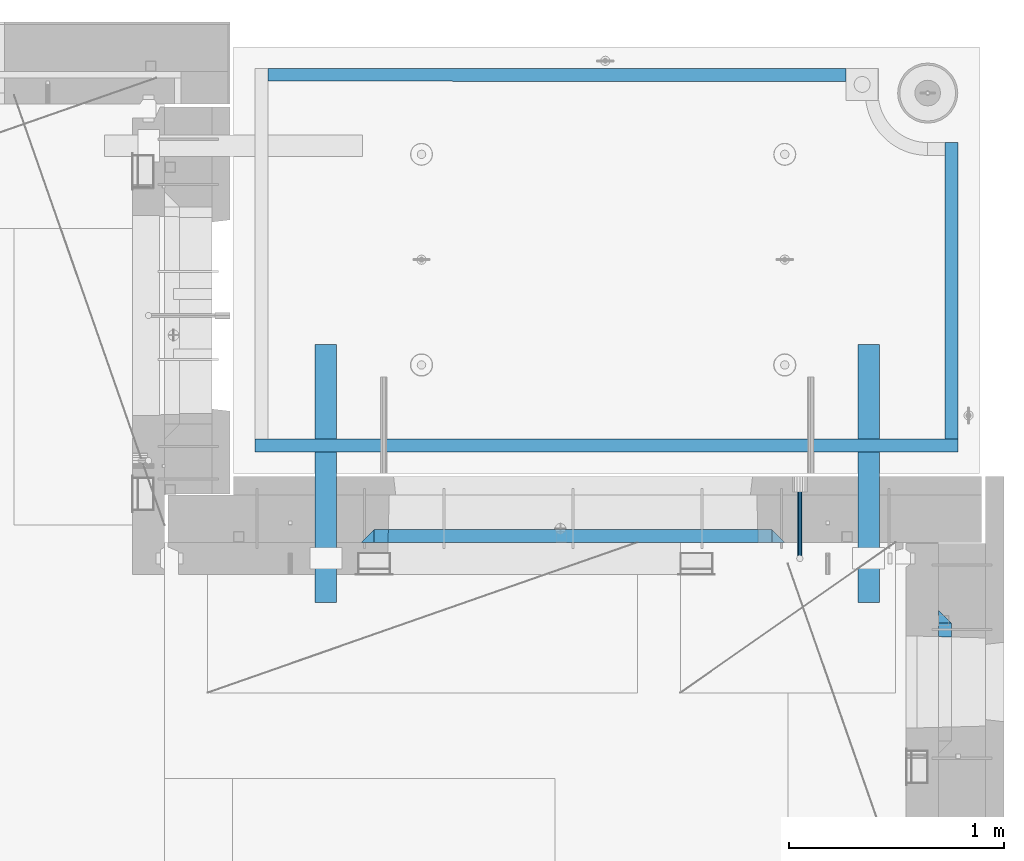
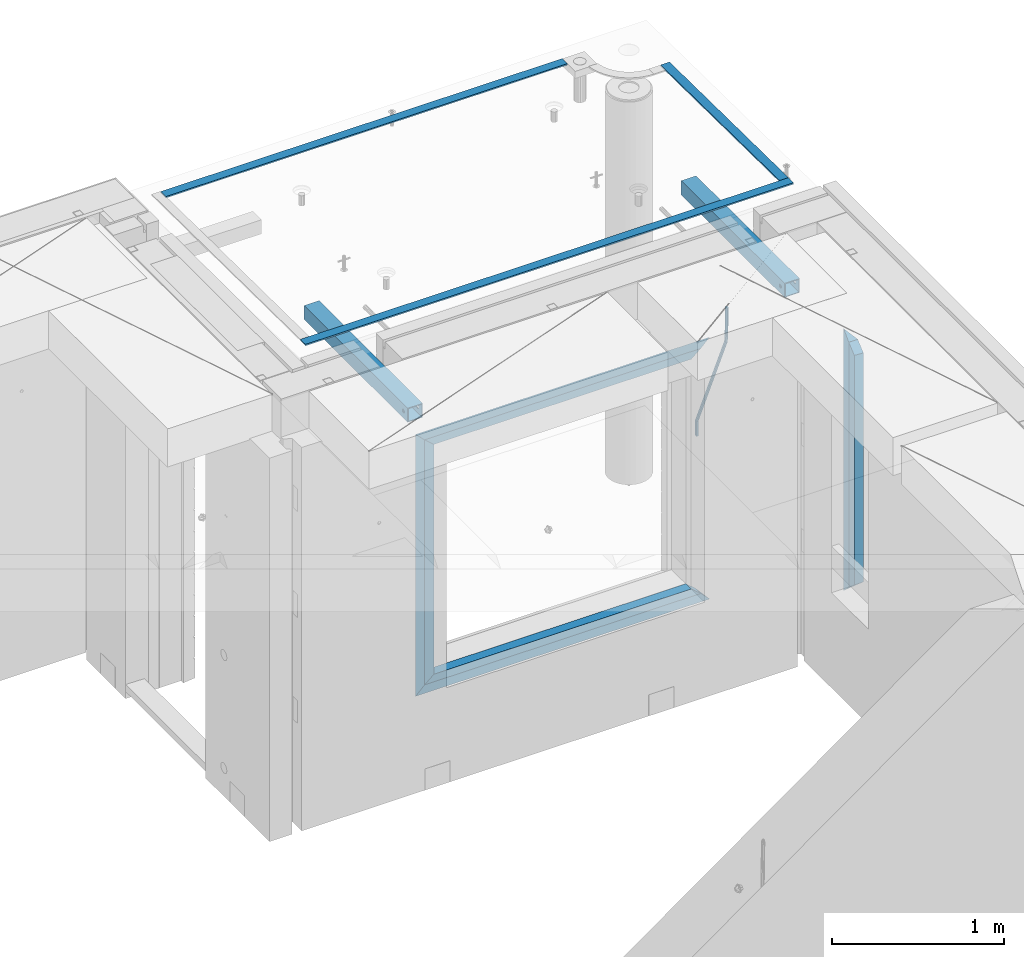
# One storey, part 135 of 350: 14 beams, 5 elements without a shape of their own.
"""IFC2X3 building model written with IfcOpenShell, lengths in millimetres."""

import ifcopenshell
import ifcopenshell.guid

model = None  # the IFC model being written
_history = None  # IfcOwnerHistory: only IFC2X3 demands one
_inside = {}  # id of a spatial element -> (the spatial element, [elements in it])
_under = {}  # id of a project, library or spatial element -> (it, [spatial elements below it])
_declared = {}  # id of a project -> (the project, [libraries it declares])
_typed = {}  # id of a type object -> (the type object, [elements of that type])
_made_of = {}  # id of a material, layer set ... -> (it, [elements and type objects made of it])


def new_model(schema):
    """Start an empty IFC model of exactly this schema.

    Asked for "IFC4X3", IfcOpenShell would pick the latest addendum, in which some entities
    have other attributes; the version numbers below select the first issue.
    IFC2X3 requires an IfcOwnerHistory on every rooted entity: one is made here for all.
    """
    global model, _history
    if schema == "IFC4X3":
        model = ifcopenshell.file(schema_version=(4, 3, 0, 0))
    else:
        model = ifcopenshell.file(schema=schema)
    _inside.clear()
    _under.clear()
    _declared.clear()
    _typed.clear()
    _made_of.clear()
    _history = None
    if model.schema == "IFC2X3":
        org = make("IfcOrganization", Name="unknown")
        user = make(
            "IfcPersonAndOrganization",
            ThePerson=make("IfcPerson", FamilyName="unknown"),
            TheOrganization=org,
        )
        app = make(
            "IfcApplication",
            ApplicationDeveloper=org,
            Version="unknown",
            ApplicationFullName="unknown",
            ApplicationIdentifier="unknown",
        )
        _history = make(
            "IfcOwnerHistory",
            OwningUser=user,
            OwningApplication=app,
            ChangeAction="ADDED",
            CreationDate=0,
        )
    return model


def make(cls, **values):
    """One entity of the class cls with the attributes given. An attribute that is None is left unset."""
    return model.create_entity(
        cls, **{name: value for name, value in values.items() if value is not None}
    )


def rooted(cls, **values):
    """An entity with a GlobalId (a new one), such as an element, a storey or a relation."""
    return make(cls, GlobalId=ifcopenshell.guid.new(), OwnerHistory=_history, **values)


def si_unit(unit_type, name, prefix=None):
    """IfcSIUnit, for example si_unit("LENGTHUNIT", "METRE", prefix="MILLI")."""
    return make("IfcSIUnit", UnitType=unit_type, Prefix=prefix, Name=name)


def assignment(units):
    """IfcUnitAssignment: the units of a project."""
    return None if units is None else make("IfcUnitAssignment", Units=units)


def point(xyz):
    """IfcCartesianPoint."""
    return None if xyz is None else make("IfcCartesianPoint", Coordinates=xyz)


def direction(xyz):
    """IfcDirection."""
    return None if xyz is None else make("IfcDirection", DirectionRatios=xyz)


def frame(location, z_axis=None, x_axis=None):
    """IfcAxis2Placement3D, a coordinate frame: its origin and axes. An axis left out is left unset."""
    return make(
        "IfcAxis2Placement3D",
        Location=point(location),
        Axis=direction(z_axis),
        RefDirection=direction(x_axis),
    )


def origin_with_axes():
    """The frame at (0, 0, 0) with the z axis (0, 0, 1) and the x axis (1, 0, 0) written out."""
    return frame((0.0, 0.0, 0.0), z_axis=(0.0, 0.0, 1.0), x_axis=(1.0, 0.0, 0.0))


def place(relative_to, where):
    """IfcLocalPlacement: puts the frame where relative to a parent placement (None: the world)."""
    return make(
        "IfcLocalPlacement", PlacementRelTo=relative_to, RelativePlacement=where
    )


def context(
    kind, dimensions, precision=None, world=None, true_north=None, identifier=None
):
    """IfcGeometricRepresentationContext, for example the 3D "Model" context."""
    return make(
        "IfcGeometricRepresentationContext",
        ContextIdentifier=identifier,
        ContextType=kind,
        CoordinateSpaceDimension=dimensions,
        Precision=precision,
        WorldCoordinateSystem=world,
        TrueNorth=true_north,
    )


def subcontext(parent, identifier, kind, view, scale=None):
    """IfcGeometricRepresentationSubContext, for example "Body" below "Model"."""
    return make(
        "IfcGeometricRepresentationSubContext",
        ContextIdentifier=identifier,
        ContextType=kind,
        ParentContext=parent,
        TargetScale=scale,
        TargetView=view,
    )


def project(units=None, contexts=None):
    """IfcProject with its units and contexts."""
    return rooted(
        "IfcProject",
        Name="project",
        RepresentationContexts=contexts,
        UnitsInContext=assignment(units),
    )


def spatial(cls, under=None, at=None, **own):
    """A site, building, storey or space (cls), placed at a placement, below another one or the project."""
    s = rooted(cls, ObjectPlacement=at, **own)
    if under is not None:
        _under.setdefault(under.id(), (under, []))[1].append(s)
    return s


def faces_of(points, faces, orient=None, outer=None):
    """IfcFace entities. A face is a list of loops; a loop is a list of indices into points, from 0.

    orient and outer hold one flag for each loop. By default every Orientation is true, the
    first loop of a face is its IfcFaceOuterBound and the others are IfcFaceBound.
    """
    made = []
    for i, loops in enumerate(faces):
        bounds = []
        for j, loop in enumerate(loops):
            is_outer = j == 0 if outer is None else outer[i][j]
            bounds.append(
                make(
                    "IfcFaceOuterBound" if is_outer else "IfcFaceBound",
                    Bound=make("IfcPolyLoop", Polygon=[points[k] for k in loop]),
                    Orientation=True if orient is None else orient[i][j],
                )
            )
        made.append(make("IfcFace", Bounds=bounds))
    return made


def faceted_brep(points, faces, orient=None, outer=None, voids=None):
    """IfcFacetedBrep: a solid bounded by flat faces; with voids (closed shells), ...WithVoids."""
    shared = [point(p) for p in points]
    hull = make("IfcClosedShell", CfsFaces=faces_of(shared, faces, orient, outer))
    if voids is None:
        return make("IfcFacetedBrep", Outer=hull)
    return make(
        "IfcFacetedBrepWithVoids",
        Outer=hull,
        Voids=[
            make(cls, CfsFaces=faces_of(shared, fs, o, b)) for cls, fs, o, b in voids
        ],
    )


def shape(context_of_items, identifier, shape_type, items):
    """IfcShapeRepresentation: the items that make up one representation, for example the "Body"."""
    return make(
        "IfcShapeRepresentation",
        ContextOfItems=context_of_items,
        RepresentationIdentifier=identifier,
        RepresentationType=shape_type,
        Items=items,
    )


def material(Name=None, Category=None):
    """IfcMaterial."""
    return make("IfcMaterial", Name=Name, Category=Category)


def made_of(thing, what):
    """Note that an element or type object is made of a material, layer set ...; save() writes the relation."""
    if what is not None:
        _made_of.setdefault(what.id(), (what, []))[1].append(thing)
    return thing


def type_object(cls, material=None, **own):
    """A type object (cls), such as IfcWallType, which elements share."""
    return made_of(rooted(cls, **own), material)


def element(
    cls,
    number,
    at=None,
    inside=None,
    cuts=None,
    type_object=None,
    material=None,
    context=None,
    identifier="Body",
    shape_type=None,
    held_by="IfcProductDefinitionShape",
    body=None,
    shapes=None,
    **own,
):
    """One element of the class cls, such as IfcWall. Its Tag is "e" and its number.

    at: its placement. inside: the storey or other place that contains it. cuts: it is an
    opening in that element (IfcRelVoidsElement). A single representation is given by context,
    identifier, shape_type and body (its items); several are given by shapes. held_by: the class
    of the entity that holds the representations. save() writes the other relations.
    """
    e = rooted(cls, Tag="e%d" % number, ObjectPlacement=at, **own)
    if body is not None:
        shapes = [shape(context, identifier, shape_type, body)]
    if shapes is not None:
        e.Representation = make(held_by, Representations=shapes)
    if inside is not None:
        _inside.setdefault(inside.id(), (inside, []))[1].append(e)
    if cuts is not None:
        rooted(
            "IfcRelVoidsElement", RelatingBuildingElement=cuts, RelatedOpeningElement=e
        )
    if type_object is not None:
        _typed.setdefault(type_object.id(), (type_object, []))[1].append(e)
    return made_of(e, material)


def aggregate(whole, parts):
    """IfcRelAggregates: a whole, such as a stair, and the parts it consists of."""
    return rooted("IfcRelAggregates", RelatingObject=whole, RelatedObjects=parts)


def save(model, path):
    """Write the relations noted so far, then the file.

    IfcRelAggregates (storeys below a building ...), IfcRelContainedInSpatialStructure (elements
    in a storey), IfcRelDefinesByType, IfcRelAssociatesMaterial and IfcRelDeclares: one each for
    every whole, place, type object, material and project.
    """
    for whole, parts in _under.values():
        aggregate(whole, parts)
    for where, things in _inside.values():
        rooted(
            "IfcRelContainedInSpatialStructure",
            RelatedElements=things,
            RelatingStructure=where,
        )
    for kind, things in _typed.values():
        rooted("IfcRelDefinesByType", RelatedObjects=things, RelatingType=kind)
    for what, things in _made_of.values():
        rooted("IfcRelAssociatesMaterial", RelatedObjects=things, RelatingMaterial=what)
    for by, libraries in _declared.values():
        rooted("IfcRelDeclares", RelatingContext=by, RelatedDefinitions=libraries)
    model.write(path)


model = new_model("IFC2X3")

# Units and contexts
model_context = context("Model", 3, precision=1e-05, world=origin_with_axes())
body_context = subcontext(model_context, "Body", "Model", "MODEL_VIEW")
ifc_project = project(units=[si_unit("LENGTHUNIT", "METRE", prefix="MILLI"), si_unit("AREAUNIT", "SQUARE_METRE"), si_unit("VOLUMEUNIT", "CUBIC_METRE"), si_unit("MASSUNIT", "GRAM", prefix="KILO"), si_unit("TIMEUNIT", "SECOND"), si_unit("PLANEANGLEUNIT", "RADIAN"), si_unit("SOLIDANGLEUNIT", "STERADIAN"), si_unit("THERMODYNAMICTEMPERATUREUNIT", "DEGREE_CELSIUS"), si_unit("LUMINOUSINTENSITYUNIT", "LUMEN")], contexts=[model_context])

# Site, building, storey
site_placement = place(None, origin_with_axes())
site = spatial("IfcSite", under=ifc_project, at=site_placement, CompositionType="ELEMENT")
building_placement = place(site_placement, origin_with_axes())
building = spatial("IfcBuilding", under=site, at=building_placement, CompositionType="ELEMENT")
storey_placement = place(building_placement, origin_with_axes())
storey = spatial("IfcBuildingStorey", under=building, at=storey_placement, Name="2", CompositionType="ELEMENT", Elevation=0.0)

# Assembly, beam
assembly_1_placement = place(storey_placement, origin_with_axes())
assembly_1 = element("IfcElementAssembly", 1, at=assembly_1_placement, inside=storey, AssemblyPlace="NOTDEFINED", PredefinedType="REINFORCEMENT_UNIT")
ifc_material_1 = material()
beam_type_1 = type_object("IfcBeamType", Name="D20", PredefinedType="NOTDEFINED")
beam_1_placement = place(assembly_1_placement, frame((34415.0000001015, 20504.9951872346, 87407.5), z_axis=(0.000415599999849905, 0.999999913638203, 4.76000000899737e-07), x_axis=(0.0, 0.0, -1.0)))
beam_1 = element("IfcBeam", 2, at=beam_1_placement, type_object=beam_type_1, material=ifc_material_1, Name="JM20", ObjectType="D20", context=body_context, shape_type="Brep", body=[
    faceted_brep([(-0.00060564729210455, -9.99999998165731, 0.0), (-0.000428079845733009, -7.07106779890455, -7.07106781186667), (119.575515501536, -7.07830994756296, -7.07106481604933), (119.575337932896, -10.0072421307195, -3.43332612828817e-06), (0.0, 0.0, -10.0), (119.575943836026, -0.00724214867295814, -9.99999700418266), (0.00042843479604926, 7.07106779888636, -7.07106781186303), (119.57637202373, 7.06382565022977, -7.07106481604933), (0.00060564729210455, 9.99999998166459, 3.63797880709171e-12), (119.576549238118, 9.99275783300072, 2.99581552098971e-06), (0.000428079845733009, 7.07106779890819, 7.07106781186667), (119.576371669405, 7.06382565024978, 7.07107080768037), (0.0, 0.0, 10.0), (119.57594333493, -0.00724214864203532, 10.0000029958155), (-0.000428434810601175, -7.07106779888272, 7.07106781186667), (119.575515147211, -7.07830994754295, 7.07107080768037), (123.00654325854, -7.07836650239551, -6.96786008391246), (122.581588830741, -10.007295666459, 0.0904344953341933), (123.182419066041, -0.00729994480025198, -9.89151006310021), (123.006190977103, 7.06376911688858, -6.96788735351402), (122.581091016109, 9.99270432680532, 0.0903895128230943), (122.156136974867, 7.06377516229986, 7.14867767459873), (121.980261167351, -0.00729139528993983, 10.0723276537792), (122.156489256289, -7.07836045697513, 7.14870494419847), (237.077376207715, -7.07551629289992, -0.0988779924864502), (236.652422053201, -10.0044409119728, 6.95941204931296), (237.253252288647, -0.0044516184279928, -3.02253250974718), (237.077024472936, 7.06661932641327, -0.0989143382521434), (236.651924624995, 9.99555908263574, 6.95936064834314), (236.226970470365, 7.06663446442326, 14.0176506898479), (236.051094389448, -0.0044302100486675, 16.9413052071086), (236.227322205144, -7.07550115488812, 14.0176870356117), (256.715938387759, -7.07353516174771, 4.66794781703175), (253.858321224223, -10.0027051854922, 11.1357628166734), (257.898622435067, -0.00236892073007766, 1.98867362452802), (256.713573090979, 7.0686002544353, 4.66742272414376), (253.85497618909, 9.99729452004976, 11.1350202234971), (250.997359025234, 7.06812449537756, 17.6028352234607), (249.814674977912, -0.00304174564189452, 20.2821094159572), (250.999724322028, -7.07401092080545, 17.6033603163596), (1009.84102825288, -6.93521658215468, 337.477148757798), (1006.98341108896, -9.86438660663771, 343.944963757851), (1011.02371230032, 0.135949658781101, 334.7978745651), (1009.83866295629, 7.20691883402651, 337.476623664521), (1006.98006605446, 10.1356130998429, 343.944221163818), (1004.12244889054, 7.2064430753635, 350.412036163872), (1002.9397648431, 0.135276834424076, 353.091310356571), (1004.12481418712, -6.93569234081951, 350.412561257146), (1010.86335274603, -6.9350288225487, 337.928918327354), (1009.37086865908, -9.86394812736762, 344.999991477531), (1011.48104818776, 0.136033652863262, 334.999973251377), (1010.86211737194, 7.20710680115553, 337.928892551665), (1009.36912157628, 10.1360518725905, 344.9999550252), (1007.87663748935, 7.2071325677698, 352.071028175378), (1007.2589420476, 0.13607009235966, 354.999973251352), (1007.87787286344, -6.93500305593261, 352.071053951067), (1011.98104820926, -6.93502881915083, 337.92891832735), (1011.98104821818, -9.86394811943501, 344.999991477524), (1011.98104818776, 0.136033654382118, 334.999973251375), (1011.98104816627, 7.20710680455704, 337.928892551661), (1011.98104815738, 10.1360518805304, 344.999955025194), (1011.98104816629, 7.20713258024625, 352.071028175369), (1011.98104818778, 0.136070106711486, 354.999973251342), (1011.98104820927, -6.9350030434598, 352.071053951058), (1117.50000002154, -6.93502849844299, 337.928918327156), (1117.50000003044, -9.86394779872717, 344.999991477331), (1117.50000000004, 0.136033975091777, 334.999973251181), (1117.49999997855, 7.20710712526488, 337.928892551467), (1117.49999996964, 10.1360522012383, 344.999955025), (1117.49999997857, 7.20713290095409, 352.071028175174), (1117.50000000006, 0.136070427419327, 354.999973251148), (1117.50000002155, -6.93500272275196, 352.071053950864)], [[[0, 1, 2, 3]], [[1, 4, 5, 2]], [[4, 6, 7, 5]], [[6, 8, 9, 7]], [[8, 10, 11, 9]], [[10, 12, 13, 11]], [[12, 14, 15, 13]], [[14, 0, 3, 15]], [[14, 12, 10, 8, 6, 4, 1, 0]], [[3, 2, 16, 17]], [[2, 5, 18, 16]], [[5, 7, 19, 18]], [[7, 9, 20, 19]], [[9, 11, 21, 20]], [[11, 13, 22, 21]], [[13, 15, 23, 22]], [[15, 3, 17, 23]], [[17, 16, 24, 25]], [[16, 18, 26, 24]], [[18, 19, 27, 26]], [[19, 20, 28, 27]], [[20, 21, 29, 28]], [[21, 22, 30, 29]], [[22, 23, 31, 30]], [[23, 17, 25, 31]], [[25, 24, 32, 33]], [[24, 26, 34, 32]], [[26, 27, 35, 34]], [[27, 28, 36, 35]], [[28, 29, 37, 36]], [[29, 30, 38, 37]], [[30, 31, 39, 38]], [[31, 25, 33, 39]], [[33, 32, 40, 41]], [[32, 34, 42, 40]], [[34, 35, 43, 42]], [[35, 36, 44, 43]], [[36, 37, 45, 44]], [[37, 38, 46, 45]], [[38, 39, 47, 46]], [[39, 33, 41, 47]], [[41, 40, 48, 49]], [[40, 42, 50, 48]], [[42, 43, 51, 50]], [[43, 44, 52, 51]], [[44, 45, 53, 52]], [[45, 46, 54, 53]], [[46, 47, 55, 54]], [[47, 41, 49, 55]], [[49, 48, 56, 57]], [[48, 50, 58, 56]], [[50, 51, 59, 58]], [[51, 52, 60, 59]], [[52, 53, 61, 60]], [[53, 54, 62, 61]], [[54, 55, 63, 62]], [[55, 49, 57, 63]], [[57, 56, 64, 65]], [[56, 58, 66, 64]], [[58, 59, 67, 66]], [[59, 60, 68, 67]], [[60, 61, 69, 68]], [[61, 62, 70, 69]], [[62, 63, 71, 70]], [[63, 57, 65, 71]], [[66, 67, 68, 69, 70, 71, 65, 64]]]),
])

# Assemblies, beams
assembly_2_placement = place(storey_placement, origin_with_axes())
assembly_2 = element("IfcElementAssembly", 3, at=assembly_2_placement, inside=storey, AssemblyPlace="NOTDEFINED", PredefinedType="REINFORCEMENT_UNIT")
assembly_3_placement = place(assembly_2_placement, origin_with_axes())
assembly_3 = element("IfcElementAssembly", 4, at=assembly_3_placement, AssemblyPlace="NOTDEFINED", PredefinedType="NOTDEFINED")
ifc_material_2 = material(Name="Undefined/350")
beam_type_2 = type_object("IfcBeamType", Name="100X100X5", PredefinedType="NOTDEFINED")
beam_2_placement = place(assembly_3_placement, frame((34735.0001432011, 21500.0034426031, 87555.0), z_axis=(0.0, 0.0, 1.0), x_axis=(-2.2242999997242e-05, -0.999999999752625, 0.0)))
beam_2 = element("IfcBeam", 5, at=beam_2_placement, type_object=beam_type_2, material=ifc_material_2, ObjectType="100X100X5", context=body_context, shape_type="Brep", body=[
    faceted_brep([(1143.75108023171, 44.9999999999982, -10.8253175473074), (1143.75107855316, 50.0255964196231, -10.8253175473074), (1139.17576100585, 50.0255948914664, -6.25), (1139.1757626844, 44.9999999999982, -6.25), (1150.00108023171, 44.9999999999982, -12.5), (1150.00107855316, 50.0255985071226, -12.5), (1156.2510802317, 44.9999999999982, -10.8253175473074), (1156.25107855315, 50.0256005946221, -10.8253175473074), (1160.82639777901, 44.9999999999982, -6.25), (1160.82639610046, 50.0256021227788, -6.25), (1162.50108023171, 44.9999999999982, 0.0), (1162.50107855316, 50.0256026821226, 0.0), (1160.82639777901, 44.9999999999982, 6.25), (1160.82639610046, 50.0256021227788, 6.25), (1156.2510802317, 44.9999999999982, 10.8253175473074), (1156.25107855315, 50.0256005946221, 10.8253175473074), (1150.00108023171, 44.9999999999982, 12.5), (1150.00107855316, 50.0255985071226, 12.5), (1143.75108023171, 44.9999999999982, 10.8253175473074), (1143.75107855316, 50.0255964196231, 10.8253175473074), (1139.1757626844, 44.9999999999982, 6.25), (1139.17576100585, 50.0255948914664, 6.25), (1137.5010802317, 44.9999999999982, 0.0), (1137.50107855316, 50.0255943321226, 0.0), (1143.75111195316, -49.9744035792783, -10.8253175473074), (1143.75111029171, -44.9999999999991, -10.8253175473074), (1139.1757927444, -44.9999999999991, -6.25), (1139.17579440585, -49.9744051074349, -6.25), (1150.00111195316, -49.9744014917787, -12.5), (1150.00111029171, -44.9999999999991, -12.5), (1156.25111195316, -49.9743994042774, -10.8253175473074), (1156.25111029171, -44.9999999999991, -10.8253175473074), (1160.82642950046, -49.9743978761207, -6.25), (1160.82642783901, -44.9999999999991, -6.25), (1162.50111195316, -49.9743973167779, 0.0), (1162.50111029171, -44.9999999999991, 0.0), (1160.82642950046, -49.9743978761207, 6.25), (1160.82642783901, -44.9999999999991, 6.25), (1156.25111195316, -49.9743994042774, 10.8253175473074), (1156.25111029171, -44.9999999999991, 10.8253175473074), (1150.00111195316, -49.9744014917787, 12.5), (1150.00111029171, -44.9999999999991, 12.5), (1143.75111195316, -49.9744035792783, 10.8253175473074), (1143.75111029171, -44.9999999999991, 10.8253175473074), (1139.17579440585, -49.9744051074349, 6.25), (1139.1757927444, -44.9999999999991, 6.25), (1137.50111195316, -49.9744056667778, 0.0), (1137.50111029171, -44.9999999999991, 0.0), (1.81898940354586e-12, -50.0000000000009, -50.0), (1.81898940354586e-12, 49.9999999999991, -50.0), (1200.00449189278, 49.9999999999982, -50.0), (1200.00449189278, -50.0000000000009, -50.0), (1.81898940354586e-12, 49.9999999999991, 50.0), (1.81898940354586e-12, -50.0000000000009, 50.0), (1200.00449189278, -50.0000000000009, 50.0), (1200.00449189278, 49.9999999999982, 50.0), (0.0, 44.9999999999991, 45.0), (1.81898940354586e-12, -45.0000000000009, 45.0), (1.81898940354586e-12, -45.0000000000009, -45.0), (0.0, 44.9999999999991, -45.0), (1200.00449189278, 44.9999999999982, -45.0), (1200.00449189278, 44.9999999999982, 45.0), (1200.00449189278, -45.0000000000009, 45.0), (1200.00449189278, -45.0000000000009, -45.0)], [[[0, 1, 2, 3]], [[4, 5, 1, 0]], [[6, 7, 5, 4]], [[8, 9, 7, 6]], [[10, 11, 9, 8]], [[12, 13, 11, 10]], [[14, 15, 13, 12]], [[16, 17, 15, 14]], [[18, 19, 17, 16]], [[20, 21, 19, 18]], [[22, 23, 21, 20]], [[3, 2, 23, 22]], [[24, 25, 26, 27]], [[28, 29, 25, 24]], [[30, 31, 29, 28]], [[32, 33, 31, 30]], [[34, 35, 33, 32]], [[36, 37, 35, 34]], [[38, 39, 37, 36]], [[40, 41, 39, 38]], [[42, 43, 41, 40]], [[44, 45, 43, 42]], [[46, 47, 45, 44]], [[27, 26, 47, 46]], [[48, 49, 50, 51]], [[52, 53, 54, 55]], [[49, 52, 55, 50], [15, 17, 19, 21, 23, 2, 1, 5, 7, 9, 11, 13]], [[48, 53, 52, 49], [56, 57, 58, 59]], [[56, 59, 60, 61], [6, 4, 0, 3, 22, 20, 18, 16, 14, 12, 10, 8]], [[57, 56, 61, 62]], [[58, 57, 62, 63], [39, 41, 43, 45, 47, 26, 25, 29, 31, 33, 35, 37]], [[59, 58, 63, 60]], [[54, 51, 50, 55], [62, 61, 60, 63]], [[53, 48, 51, 54], [30, 28, 24, 27, 46, 44, 42, 40, 38, 36, 34, 32]]]),
])
aggregate(assembly_3, [beam_2])
assembly_4_placement = place(assembly_2_placement, origin_with_axes())
assembly_4 = element("IfcElementAssembly", 6, at=assembly_4_placement, AssemblyPlace="NOTDEFINED", PredefinedType="NOTDEFINED")
beam_3_placement = place(assembly_4_placement, frame((32210.0001432011, 21500.0034426031, 87555.0), z_axis=(0.0, 0.0, 1.0), x_axis=(-2.2242999997242e-05, -0.999999999752625, 0.0)))
beam_3 = element("IfcBeam", 7, at=beam_3_placement, type_object=beam_type_2, material=ifc_material_2, ObjectType="100X100X5", context=body_context, shape_type="Brep", body=[
    faceted_brep([(1143.75108023171, 44.9999999999982, -10.8253175473074), (1143.75107855316, 50.0255964196231, -10.8253175473074), (1139.17576100585, 50.0255948914664, -6.25), (1139.1757626844, 44.9999999999982, -6.25), (1150.00108023171, 44.9999999999982, -12.5), (1150.00107855316, 50.0255985071226, -12.5), (1156.2510802317, 44.9999999999982, -10.8253175473074), (1156.25107855315, 50.0256005946221, -10.8253175473074), (1160.82639777901, 44.9999999999982, -6.25), (1160.82639610046, 50.0256021227788, -6.25), (1162.50108023171, 44.9999999999982, 0.0), (1162.50107855316, 50.0256026821226, 0.0), (1160.82639777901, 44.9999999999982, 6.25), (1160.82639610046, 50.0256021227788, 6.25), (1156.2510802317, 44.9999999999982, 10.8253175473074), (1156.25107855315, 50.0256005946221, 10.8253175473074), (1150.00108023171, 44.9999999999982, 12.5), (1150.00107855316, 50.0255985071226, 12.5), (1143.75108023171, 44.9999999999982, 10.8253175473074), (1143.75107855316, 50.0255964196231, 10.8253175473074), (1139.1757626844, 44.9999999999982, 6.25), (1139.17576100585, 50.0255948914664, 6.25), (1137.5010802317, 44.9999999999982, 0.0), (1137.50107855316, 50.0255943321226, 0.0), (1143.75111195316, -49.9744035792783, -10.8253175473074), (1143.75111029171, -44.9999999999991, -10.8253175473074), (1139.1757927444, -44.9999999999991, -6.25), (1139.17579440585, -49.9744051074349, -6.25), (1150.00111195316, -49.9744014917787, -12.5), (1150.00111029171, -44.9999999999991, -12.5), (1156.25111195316, -49.9743994042774, -10.8253175473074), (1156.25111029171, -44.9999999999991, -10.8253175473074), (1160.82642950046, -49.9743978761207, -6.25), (1160.82642783901, -44.9999999999991, -6.25), (1162.50111195316, -49.9743973167779, 0.0), (1162.50111029171, -44.9999999999991, 0.0), (1160.82642950046, -49.9743978761207, 6.25), (1160.82642783901, -44.9999999999991, 6.25), (1156.25111195316, -49.9743994042774, 10.8253175473074), (1156.25111029171, -44.9999999999991, 10.8253175473074), (1150.00111195316, -49.9744014917787, 12.5), (1150.00111029171, -44.9999999999991, 12.5), (1143.75111195316, -49.9744035792783, 10.8253175473074), (1143.75111029171, -44.9999999999991, 10.8253175473074), (1139.17579440585, -49.9744051074349, 6.25), (1139.1757927444, -44.9999999999991, 6.25), (1137.50111195316, -49.9744056667778, 0.0), (1137.50111029171, -44.9999999999991, 0.0), (1.81898940354586e-12, -50.0000000000009, -50.0), (1.81898940354586e-12, 49.9999999999991, -50.0), (1200.00449189278, 49.9999999999982, -50.0), (1200.00449189278, -50.0000000000009, -50.0), (1.81898940354586e-12, 49.9999999999991, 50.0), (1.81898940354586e-12, -50.0000000000009, 50.0), (1200.00449189278, -50.0000000000009, 50.0), (1200.00449189278, 49.9999999999982, 50.0), (0.0, 44.9999999999991, 45.0), (1.81898940354586e-12, -45.0000000000009, 45.0), (1.81898940354586e-12, -45.0000000000009, -45.0), (0.0, 44.9999999999991, -45.0), (1200.00449189278, 44.9999999999982, -45.0), (1200.00449189278, 44.9999999999982, 45.0), (1200.00449189278, -45.0000000000009, 45.0), (1200.00449189278, -45.0000000000009, -45.0)], [[[0, 1, 2, 3]], [[4, 5, 1, 0]], [[6, 7, 5, 4]], [[8, 9, 7, 6]], [[10, 11, 9, 8]], [[12, 13, 11, 10]], [[14, 15, 13, 12]], [[16, 17, 15, 14]], [[18, 19, 17, 16]], [[20, 21, 19, 18]], [[22, 23, 21, 20]], [[3, 2, 23, 22]], [[24, 25, 26, 27]], [[28, 29, 25, 24]], [[30, 31, 29, 28]], [[32, 33, 31, 30]], [[34, 35, 33, 32]], [[36, 37, 35, 34]], [[38, 39, 37, 36]], [[40, 41, 39, 38]], [[42, 43, 41, 40]], [[44, 45, 43, 42]], [[46, 47, 45, 44]], [[27, 26, 47, 46]], [[48, 49, 50, 51]], [[52, 53, 54, 55]], [[49, 52, 55, 50], [15, 17, 19, 21, 23, 2, 1, 5, 7, 9, 11, 13]], [[48, 53, 52, 49], [56, 57, 58, 59]], [[56, 59, 60, 61], [6, 4, 0, 3, 22, 20, 18, 16, 14, 12, 10, 8]], [[57, 56, 61, 62]], [[58, 57, 62, 63], [39, 41, 43, 45, 47, 26, 25, 29, 31, 33, 35, 37]], [[59, 58, 63, 60]], [[54, 51, 50, 55], [62, 61, 60, 63]], [[53, 48, 51, 54], [30, 28, 24, 27, 46, 44, 42, 40, 38, 36, 34, 32]]]),
])
aggregate(assembly_4, [beam_3])
ifc_material_3 = material(Name="CONCRETE/Concrete_Undefined")
beam_type_3 = type_object("IfcBeamType", PredefinedType="NOTDEFINED")
beam_4_placement = place(assembly_2_placement, frame((31939.9962088653, 22755.0460044164, 87704.8214945677), z_axis=(-6.06120000110142e-05, 1.00000033869885e-09, 0.999999998163093), x_axis=(0.999999998046552, -1.52670000006885e-05, 6.06120000021532e-05)))
beam_4 = element("IfcBeam", 8, at=beam_4_placement, type_object=beam_type_3, material=ifc_material_3, context=body_context, shape_type="Brep", body=[
    faceted_brep([(2.5465851649642e-11, 29.9999999999982, -4.99999999998545), (-2.91038304567337e-11, 29.9999999999982, 5.0), (2689.99575395095, 29.9999999999964, 5.0), (2689.99575395095, 30.0000000000036, -4.99999999998545), (-2.5465851649642e-11, -30.0000000000018, 5.0), (2689.99575395095, -30.0000000000036, 5.00000000001455), (2.72848410531878e-11, -30.0000000000018, -4.99999999998545), (2689.99575395095, -29.9999999999964, -4.99999999998545)], [[[0, 1, 2, 3]], [[1, 4, 5, 2]], [[4, 6, 7, 5]], [[6, 0, 3, 7]], [[5, 7, 3, 2]], [[6, 4, 1, 0]]]),
])
beam_5_placement = place(assembly_2_placement, frame((35120.0586113047, 21059.9283388168, 87725.6638339053), z_axis=(-5.46000002942176e-07, 0.0130421150000144, 0.999914948001093), x_axis=(-4.18520000064741e-05, 0.999914947125351, -0.0130421150016393)))
beam_5 = element("IfcBeam", 9, at=beam_5_placement, type_object=beam_type_3, material=ifc_material_3, context=body_context, shape_type="Brep", body=[
    faceted_brep([(2.5465851649642e-11, 29.9999999999982, -4.99999999998545), (-2.91038304567337e-11, 29.9999999999982, 5.0), (1380.14316164461, 30.0, 5.00000000001455), (1380.1431616447, 29.9999999999927, -5.0), (-2.5465851649642e-11, -30.0000000000018, 5.0), (1380.14316164461, -30.0, 5.00000000001455), (2.72848410531878e-11, -30.0000000000018, -4.99999999998545), (1380.1431616447, -30.0, -5.0)], [[[0, 1, 2, 3]], [[1, 4, 5, 2]], [[4, 6, 7, 5]], [[6, 0, 3, 7]], [[5, 7, 3, 2]], [[6, 4, 1, 0]]]),
])
beam_6_placement = place(assembly_2_placement, frame((31879.9986204165, 21030.068155681, 87725.2788443041), z_axis=(-0.000117617000009658, 3.00000101585662e-09, 0.999999993083121), x_axis=(0.999999992839137, -2.20899999960382e-05, 0.000117616999982089)))
beam_6 = element("IfcBeam", 10, at=beam_6_placement, type_object=beam_type_3, material=ifc_material_3, context=body_context, shape_type="Brep", body=[
    faceted_brep([(2.5465851649642e-11, 29.9999999999982, -4.99999999998545), (-2.91038304567337e-11, 29.9999999999982, 5.0), (3270.06002088557, 30.0, 5.0), (3270.06002088557, 30.0000000000036, -5.0), (-2.5465851649642e-11, -30.0000000000018, 5.0), (3270.06002088557, -30.0, 5.0), (2.72848410531878e-11, -30.0000000000018, -4.99999999998545), (3270.06002088558, -29.9999999999964, -5.0)], [[[0, 1, 2, 3]], [[1, 4, 5, 2]], [[4, 6, 7, 5]], [[6, 0, 3, 7]], [[5, 7, 3, 2]], [[6, 4, 1, 0]]]),
])
aggregate(assembly_2, [assembly_3, assembly_4, beam_4, beam_5, beam_6])

# Assembly, beam
assembly_5_placement = place(storey_placement, origin_with_axes())
assembly_5 = element("IfcElementAssembly", 11, at=assembly_5_placement, inside=storey, AssemblyPlace="NOTDEFINED", PredefinedType="REINFORCEMENT_UNIT")
ifc_material_4 = material(Name="CONCRETE/C25/30")
beam_type_4 = type_object("IfcBeamType", PredefinedType="NOTDEFINED")
beam_7_placement = place(assembly_5_placement, frame((35090.0, 20234.9999664753, 87175.0), z_axis=(0.0, -1.0, 0.0), x_axis=(0.0, 0.0, -1.0)))
beam_7 = element("IfcBeam", 12, at=beam_7_placement, type_object=beam_type_4, material=ifc_material_4, Name="SK", context=body_context, shape_type="Brep", body=[
    faceted_brep([(60.0000000000073, 30.0, 30.0), (0.0, -30.0, -30.0), (60.0000000000073, -30.0, 30.0), (1795.00000000001, 30.0, 30.0), (1855.0, -30.0, -30.0), (1795.00000000001, -30.0, 30.0)], [[[0, 1, 2]], [[3, 4, 1, 0]], [[4, 5, 2, 1]], [[5, 3, 0, 2]], [[5, 4, 3]]]),
])

# Beam
beam_8_placement = place(assembly_1_placement, frame((34345.0010086818, 20609.9951872276, 87145.0), z_axis=(0.0, 0.0, -1.0), x_axis=(-1.0, 3.00000001838171e-08, 0.0)))
beam_8 = element("IfcBeam", 13, at=beam_8_placement, type_object=beam_type_4, material=ifc_material_4, Name="SK", context=body_context, shape_type="Brep", body=[
    faceted_brep([(60.0000000000073, 30.0, 30.0), (0.0, -30.0, -30.0), (60.0000000000073, -30.0, 30.0), (1910.00076293945, 30.0, 30.0), (1970.00076293945, -30.0, -30.0), (1910.00076293945, -30.0, 30.0)], [[[0, 1, 2]], [[1, 0, 3, 4]], [[2, 1, 4, 5]], [[0, 2, 5, 3]], [[4, 3, 5]]]),
])

beam_9_placement = place(assembly_1_placement, frame((34285.0010086818, 20609.9951872276, 87085.0), z_axis=(0.0, 0.0, -1.0), x_axis=(-1.0, 3.00000001838171e-08, 0.0)))
beam_9 = element("IfcBeam", 14, at=beam_9_placement, type_object=beam_type_4, material=ifc_material_4, Name="SK", context=body_context, shape_type="Brep", body=[
    faceted_brep([(64.0548169935064, -30.0, 24.9041288395529), (65.6764386151262, 30.0, 26.294090229203), (0.0, 30.0, -30.0), (0.0, -30.0, -30.0), (64.0548169935064, -30.0, 24.0540540540533), (65.6764386151262, 30.0, 25.6756756756804), (1785.9467088854, -30.0, 24.0540540540533), (1784.32508726378, 30.0, 25.6756756756804), (1784.32508726378, 30.0, 26.2934362810774), (1850.00076293945, 30.0, -30.0), (1850.00076293945, -30.0, -30.0), (1785.9467088854, -30.0, 24.9034748914128)], [[[0, 1, 2, 3]], [[4, 5, 1, 0]], [[6, 7, 5, 4]], [[2, 1, 5, 7, 8, 9]], [[3, 2, 9, 10]], [[6, 4, 0, 3, 10, 11]], [[7, 6, 11, 8]], [[10, 9, 8, 11]]]),
])

beam_10_placement = place(assembly_1_placement, frame((32405.0002457424, 20609.9951872276, 87175.0), z_axis=(1.0, 0.0, 0.0), x_axis=(0.0, 0.0, -1.0)))
beam_10 = element("IfcBeam", 15, at=beam_10_placement, type_object=beam_type_4, material=ifc_material_4, Name="SK", context=body_context, shape_type="Brep", body=[
    faceted_brep([(60.0000000000073, 30.0, 30.0), (0.0, -30.0, -30.0), (60.0000000000073, -30.0, 30.0), (1795.00000000001, 30.0, 30.0), (1855.0, -30.0, -30.0), (1795.00000000001, -30.0, 30.0)], [[[0, 1, 2]], [[3, 4, 1, 0]], [[4, 5, 2, 1]], [[5, 3, 0, 2]], [[5, 4, 3]]]),
])

beam_11_placement = place(assembly_1_placement, frame((32375.0002457424, 20609.9951872276, 85350.0), z_axis=(0.0, 0.0, 1.0), x_axis=(1.0, 0.0, 0.0)))
beam_11 = element("IfcBeam", 16, at=beam_11_placement, type_object=beam_type_4, material=ifc_material_4, Name="SK", context=body_context, shape_type="Brep", body=[
    faceted_brep([(1970.00076293945, -30.0, -30.0), (1910.00076293945, 30.0, 30.0), (1910.00076293945, -30.0, 30.0), (60.0000000000073, 30.0, 30.0), (60.0000000000073, -30.0, 30.0), (0.0, -30.0, -30.0)], [[[0, 1, 2]], [[3, 4, 2, 1]], [[4, 5, 0, 2]], [[5, 3, 1, 0]], [[3, 5, 4]]]),
])

beam_12_placement = place(assembly_1_placement, frame((32435.0002457424, 20609.9951872276, 85410.0), z_axis=(0.0, 0.0, 1.0), x_axis=(1.0, 0.0, 0.0)))
beam_12 = element("IfcBeam", 17, at=beam_12_placement, type_object=beam_type_4, material=ifc_material_4, Name="SK", context=body_context, shape_type="Brep", body=[
    faceted_brep([(1785.94594594595, -30.0, 24.9041288395238), (1850.00076293945, -30.0, -30.0), (1850.00076293945, 30.0, -30.0), (1784.32432432433, 30.0, 26.2940902291739), (1784.32432432433, 30.0, 25.6756756756804), (1785.94594594595, -30.0, 24.0540540540533), (65.6756756756768, 30.0, 25.6756756756804), (64.0540540540533, -30.0, 24.0540540540533), (65.6756756756768, 30.0, 26.293436281092), (64.0540540540533, -30.0, 24.9034748914419), (0.0, -30.0, -30.0), (0.0, 30.0, -30.0)], [[[0, 1, 2, 3]], [[4, 5, 0, 3]], [[5, 4, 6, 7]], [[7, 6, 8, 9]], [[1, 0, 5, 7, 9, 10]], [[10, 11, 2, 1]], [[6, 4, 3, 2, 11, 8]], [[10, 9, 8, 11]]]),
])

beam_type_5 = type_object("IfcBeamType", PredefinedType="NOTDEFINED")
beam_13_placement = place(assembly_5_placement, frame((35090.0, 20169.9999664753, 87115.0), z_axis=(0.0, -1.0, 0.0), x_axis=(0.0, 0.0, -1.0)))
beam_13 = element("IfcBeam", 18, at=beam_13_placement, type_object=beam_type_5, material=ifc_material_4, Name="SK", context=body_context, shape_type="Brep", body=[
    faceted_brep([(0.0, -30.0, -35.0), (54.9034748914273, -30.0, 29.0540540540533), (56.2934362811066, 30.0, 30.6756756756768), (0.0, 30.0, -35.0), (1735.0, 30.0, -35.0), (1735.0, -30.0, -35.0), (1680.09652510857, -30.0, 29.0540540540533), (1678.70656371891, 30.0, 30.6756756756768)], [[[0, 1, 2, 3]], [[4, 5, 0, 3]], [[1, 0, 5, 6]], [[2, 1, 6, 7]], [[3, 2, 7, 4]], [[5, 4, 7, 6]]]),
])

aggregate(assembly_5, [beam_7, beam_13])

beam_14_placement = place(assembly_1_placement, frame((32470.0002457424, 20609.9951872276, 87115.0), z_axis=(1.0, 0.0, 0.0), x_axis=(0.0, 0.0, -1.0)))
beam_14 = element("IfcBeam", 19, at=beam_14_placement, type_object=beam_type_5, material=ifc_material_4, Name="SK", context=body_context, shape_type="Brep", body=[
    faceted_brep([(0.0, -30.0, -35.0), (54.9034748914273, -30.0, 29.0540540540533), (56.2934362811066, 30.0, 30.6756756756768), (0.0, 30.0, -35.0), (1678.70656371891, 30.0, 30.6756756756768), (1735.0, 30.0, -35.0), (1735.0, -30.0, -35.0), (1680.09652510857, -30.0, 29.0540540540533)], [[[0, 1, 2, 3]], [[3, 2, 4, 5]], [[5, 6, 0, 3]], [[1, 0, 6, 7]], [[2, 1, 7, 4]], [[6, 5, 4, 7]]]),
])

aggregate(assembly_1, [beam_1, beam_8, beam_9, beam_10, beam_14, beam_11, beam_12])

save(model, "model.ifc")
